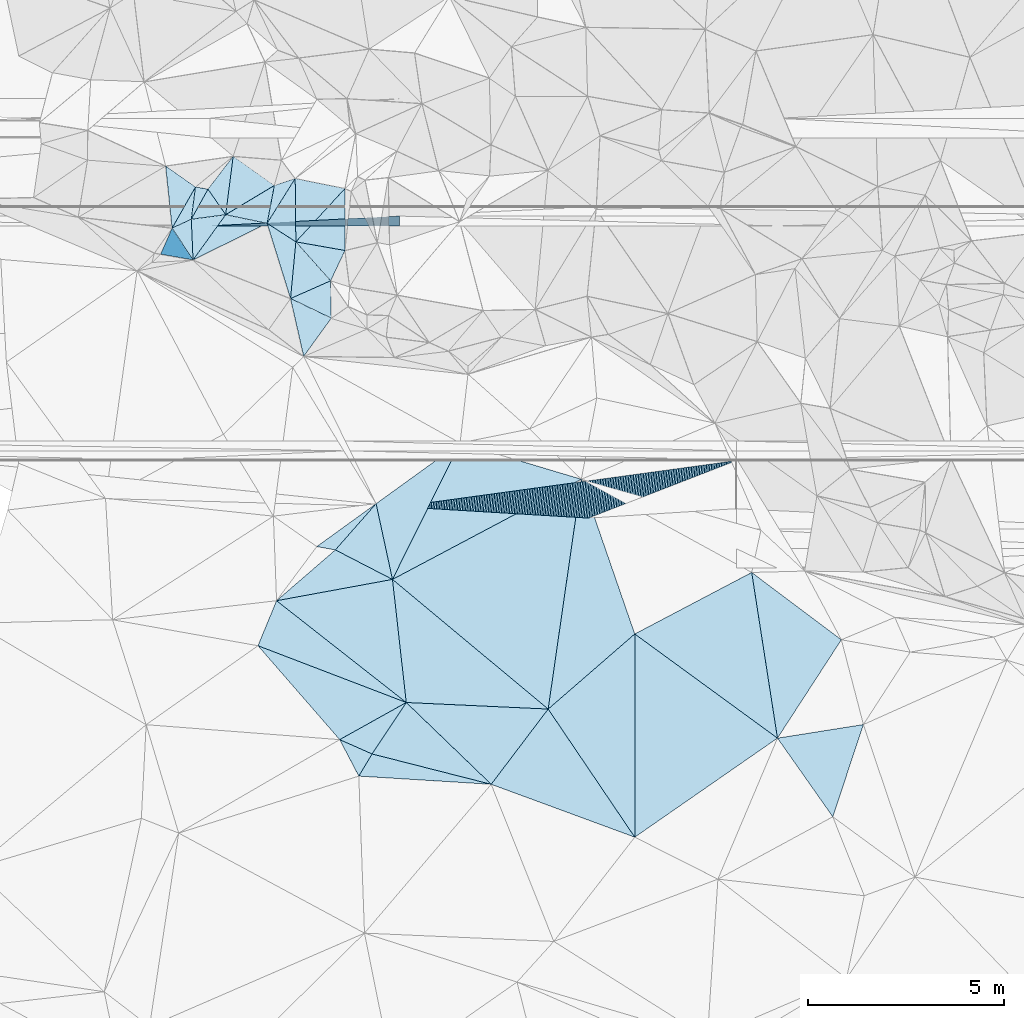
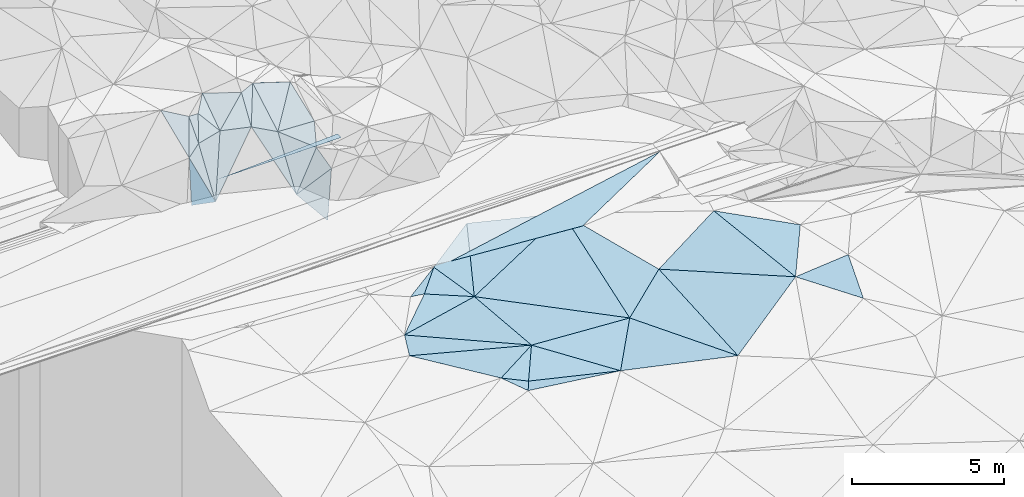
# One storey, part 46 of 275: 48 plates.
"""IFC2X3 building model written with IfcOpenShell, lengths in millimetres."""

from ifc_helpers import new_model, si_unit, frame, origin_with_axes, place, context, subcontext, project, spatial, polyline, outline, extrude, material, type_object, element, save


model = new_model("IFC2X3")

# Units and contexts
model_context = context("Model", 3, precision=1e-05, world=origin_with_axes())
body_context = subcontext(model_context, "Body", "Model", "MODEL_VIEW")
ifc_project = project(units=[si_unit("LENGTHUNIT", "METRE", prefix="MILLI"), si_unit("AREAUNIT", "SQUARE_METRE"), si_unit("VOLUMEUNIT", "CUBIC_METRE"), si_unit("MASSUNIT", "GRAM", prefix="KILO"), si_unit("TIMEUNIT", "SECOND"), si_unit("PLANEANGLEUNIT", "RADIAN"), si_unit("SOLIDANGLEUNIT", "STERADIAN"), si_unit("THERMODYNAMICTEMPERATUREUNIT", "DEGREE_CELSIUS"), si_unit("LUMINOUSINTENSITYUNIT", "LUMEN")], contexts=[model_context])

# Site, building, storey
site_placement = place(None, origin_with_axes())
site = spatial("IfcSite", under=ifc_project, at=site_placement, CompositionType="ELEMENT")
building_placement = place(site_placement, origin_with_axes())
building = spatial("IfcBuilding", under=site, at=building_placement, Name="Undefined", CompositionType="ELEMENT")
storey_placement = place(building_placement, origin_with_axes())
storey = spatial("IfcBuildingStorey", under=building, at=storey_placement, Name="Undefined", CompositionType="ELEMENT", Elevation=0.0)

# Plates
ifc_material = material()
plate_type_1 = type_object("IfcPlateType", PredefinedType="NOTDEFINED")
for number, where, z_axis, x_axis, name in (
    (1, (-134278.700031969, 66044.5731858637, 48859.6831648337), (0.00832149793297365, -0.0249918019511436, -0.9996530210565), (0.998643774165445, 0.0515876520399851, 0.00702328111339566), "00_PR"),
    (2, (-134278.700031969, 66044.5731858637, 48859.6831648337), (0.00832149793297365, -0.0249918019511436, -0.9996530210565), (0.998643774165445, 0.0515876520399851, 0.00702328111339566), "00_PR"),
    (3, (-134278.700031969, 66044.5731858637, 48859.6831648337), (0.00832149793297365, -0.0249918019511436, -0.9996530210565), (0.998643774165445, 0.0515876520399851, 0.00702328111339566), "00_PR"),
):
    element("IfcPlate", number, at=place(storey_placement, frame(where, z_axis=z_axis, x_axis=x_axis)), inside=storey, type_object=plate_type_1, material=ifc_material, Name=name, context=body_context, shape_type="SweptSolid", body=[
        extrude(outline(polyline([(0.0, 0.0), (4840.75732421875, -1.19907781481743e-08), (4827.89013671875, 249.746856689453), (0.0, 0.0)])), frame((-8.85201319254618e-08, 2.18876761149539e-07, -0.5000001331573), z_axis=(0.0, 0.0, 1.0), x_axis=(1.0, 0.0, 0.0)), (0.0, 0.0, 1.0), 1.0),
    ])
plate_type_2 = type_object("IfcPlateType", PredefinedType="NOTDEFINED")
plate_1_placement = place(storey_placement, frame((-132105.806070304, 67257.3645865039, 51279.5756660322), z_axis=(0.143488431826918, 0.509159641083011, -0.848626849577641), x_axis=(0.00906189024525655, -0.858140283939248, -0.513335304869877)))
element("IfcPlate", 4, at=plate_1_placement, inside=storey, type_object=plate_type_2, material=ifc_material, Name="00", context=body_context, shape_type="SweptSolid", body=[
    extrude(outline(polyline([(0.0, 0.0), (1889.60314941406, -3.17231751978397e-09), (1394.41979980469, 737.355712890625), (0.0, 0.0)])), frame((-8.85201319254618e-08, 2.18876761149539e-07, -0.5000001331573), z_axis=(0.0, 0.0, 1.0), x_axis=(1.0, 0.0, 0.0)), (0.0, 0.0, 1.0), 1.0),
])
plate_type_3 = type_object("IfcPlateType", PredefinedType="NOTDEFINED")
plate_2_placement = place(storey_placement, frame((-134654.734859976, 67037.9861247674, 50969.5864879474), z_axis=(0.194931186633535, 0.527354680632889, -0.826981785344893), x_axis=(0.977887294368725, -0.16961479988907, 0.122340750246206)))
element("IfcPlate", 5, at=plate_2_placement, inside=storey, type_object=plate_type_3, material=ifc_material, Name="00", context=body_context, shape_type="SweptSolid", body=[
    extrude(outline(polyline([(0.0, 0.0), (326.955657958984, 4.16184775531292e-09), (-31.502742767334, 995.242492675781), (0.0, 0.0)])), frame((-8.85201319254618e-08, 2.18876761149539e-07, -0.5000001331573), z_axis=(0.0, 0.0, 1.0), x_axis=(1.0, 0.0, 0.0)), (0.0, 0.0, 1.0), 1.0),
])
plate_type_4 = type_object("IfcPlateType", PredefinedType="NOTDEFINED")
plate_3_placement = place(storey_placement, frame((-130037.691105596, 58943.436849099, 48209.4999821093), z_axis=(-0.00131063093471939, -0.00730660715273056, -0.999972447489664), x_axis=(-0.660969339746137, -0.750386046708085, 0.00634923785720053)))
element("IfcPlate", 6, at=plate_3_placement, inside=storey, type_object=plate_type_4, material=ifc_material, Name="00", context=body_context, shape_type="SweptSolid", body=[
    extrude(outline(polyline([(0.0, 0.0), (1574.99206542969, 1.43772922456265e-08), (1825.02502441406, 412.775360107422), (0.0, 0.0)])), frame((-8.85201319254618e-08, 2.18876761149539e-07, -0.5000001331573), z_axis=(0.0, 0.0, 1.0), x_axis=(1.0, 0.0, 0.0)), (0.0, 0.0, 1.0), 1.0),
])
plate_type_5 = type_object("IfcPlateType", PredefinedType="NOTDEFINED")
plate_4_placement = place(storey_placement, frame((-132822.78437554, 66109.4902628047, 50469.673303654), z_axis=(0.304659948241658, 0.693047229450227, -0.653351248325703), x_axis=(0.826595257870964, -0.533188552703511, -0.180139520736486)))
element("IfcPlate", 7, at=plate_4_placement, inside=storey, type_object=plate_type_5, material=ifc_material, Name="00", context=body_context, shape_type="SweptSolid", body=[
    extrude(outline(polyline([(0.0, 0.0), (888.200439453125, -1.60434865392745e-09), (1836.5224609375, 1943.62683105469), (0.0, 0.0)])), frame((-8.85201319254618e-08, 2.18876761149539e-07, -0.5000001331573), z_axis=(0.0, 0.0, 1.0), x_axis=(1.0, 0.0, 0.0)), (0.0, 0.0, 1.0), 1.0),
])
plate_type_6 = type_object("IfcPlateType", PredefinedType="NOTDEFINED")
plate_5_placement = place(storey_placement, frame((-129266.871286603, 53861.2405189074, 47899.5134927947), z_axis=(-0.0107983850297951, 0.230769056659911, -0.972948630385512), x_axis=(0.998692726079005, -0.0461274773168914, -0.0220248657944936)))
element("IfcPlate", 8, at=plate_5_placement, inside=storey, type_object=plate_type_6, material=ifc_material, Name="00", context=body_context, shape_type="SweptSolid", body=[
    extrude(outline(polyline([(0.0, 0.0), (3632.25830078125, 2.32394086197019e-08), (2275.82934570313, 2043.20837402344), (0.0, 0.0)])), frame((-8.85201319254618e-08, 2.18876761149539e-07, -0.5000001331573), z_axis=(0.0, 0.0, 1.0), x_axis=(1.0, 0.0, 0.0)), (0.0, 0.0, 1.0), 1.0),
])
plate_type_7 = type_object("IfcPlateType", PredefinedType="NOTDEFINED")
for number, where, z_axis, x_axis, name in (
    (9, (-120830.616385825, 60044.0391399351, 48952.9577921263), (0.0074723662007596, 0.44720202102918, -0.89440176438264), (-0.915882799607801, -0.355950908885757, -0.185627713033319), "00_PR"),
    (10, (-120830.616385825, 60044.0391399351, 48952.9577921263), (0.0074723662007596, 0.44720202102918, -0.89440176438264), (-0.915882799607801, -0.355950908885757, -0.185627713033319), "00_PR"),
    (11, (-120830.616385825, 60044.0391399351, 48952.9577921263), (0.0074723662007596, 0.44720202102918, -0.89440176438264), (-0.915882799607801, -0.355950908885757, -0.185627713033319), "00_PR"),
):
    element("IfcPlate", number, at=place(storey_placement, frame(where, z_axis=z_axis, x_axis=x_axis)), inside=storey, type_object=plate_type_7, material=ifc_material, Name=name, context=body_context, shape_type="SweptSolid", body=[
        extrude(outline(polyline([(0.0, 0.0), (4127.33642578125, 1.97178451344371e-08), (8431.79296875, 2221.81469726563), (0.0, 0.0)])), frame((-8.85201319254618e-08, 2.18876761149539e-07, -0.5000001331573), z_axis=(0.0, 0.0, 1.0), x_axis=(1.0, 0.0, 0.0)), (0.0, 0.0, 1.0), 1.0),
    ])
plate_type_8 = type_object("IfcPlateType", PredefinedType="NOTDEFINED")
plate_6_placement = place(storey_placement, frame((-133690.586690186, 67824.8999073513, 51089.5456571507), z_axis=(0.300861697588153, 0.289564330805991, -0.908644450403596), x_axis=(0.812040488573359, -0.577396749498086, 0.0848718951513678)))
element("IfcPlate", 12, at=plate_6_placement, inside=storey, type_object=plate_type_8, material=ifc_material, Name="00", context=body_context, shape_type="SweptSolid", body=[
    extrude(outline(polyline([(0.0, 0.0), (1296.07104492188, 4.29645297117531e-09), (661.769287109375, 1458.13623046875), (0.0, 0.0)])), frame((-8.85201319254618e-08, 2.18876761149539e-07, -0.5000001331573), z_axis=(0.0, 0.0, 1.0), x_axis=(1.0, 0.0, 0.0)), (0.0, 0.0, 1.0), 1.0),
])
plate_type_9 = type_object("IfcPlateType", PredefinedType="NOTDEFINED")
plate_7_placement = place(storey_placement, frame((-134760.923733724, 66214.7455942804, 50419.5874471003), z_axis=(0.211448494305168, 0.523954918942359, -0.825082285091726), x_axis=(-0.811240907543192, -0.376753294045777, -0.447152261935635)))
element("IfcPlate", 13, at=plate_7_placement, inside=storey, type_object=plate_type_9, material=ifc_material, Name="00", context=body_context, shape_type="SweptSolid", body=[
    extrude(outline(polyline([(0.0, 0.0), (603.821166992188, 3.78349795937538e-09), (-642.2431640625, 760.936096191406), (0.0, 0.0)])), frame((-8.85201319254618e-08, 2.18876761149539e-07, -0.5000001331573), z_axis=(0.0, 0.0, 1.0), x_axis=(1.0, 0.0, 0.0)), (0.0, 0.0, 1.0), 1.0),
])
plate_type_10 = type_object("IfcPlateType", PredefinedType="NOTDEFINED")
plate_8_placement = place(storey_placement, frame((-134716.304775006, 65174.1068414552, 48689.7760835794), z_axis=(0.124226424866957, 0.885466580296215, -0.447790945133219), x_axis=(-0.982237248685454, 0.173699449781351, 0.0709823107575806)))
element("IfcPlate", 14, at=plate_8_placement, inside=storey, type_object=plate_type_10, material=ifc_material, Name="00", context=body_context, shape_type="SweptSolid", body=[
    extrude(outline(polyline([(0.0, 0.0), (845.281005859375, 6.63567334413528e-09), (769.921447753906, 1576.71203613281), (0.0, 0.0)])), frame((-8.85201319254618e-08, 2.18876761149539e-07, -0.5000001331573), z_axis=(0.0, 0.0, 1.0), x_axis=(1.0, 0.0, 0.0)), (0.0, 0.0, 1.0), 1.0),
])
plate_9_placement = place(storey_placement, frame((-130968.464173493, 52912.2200565433, 47749.5251208357), z_axis=(-0.084485952416159, 0.301574840152359, -0.949691918272138), x_axis=(0.870762785628909, 0.485674587583211, 0.0767617491962)))
element("IfcPlate", 15, at=plate_9_placement, inside=storey, type_object=plate_type_10, material=ifc_material, Name="00", context=body_context, shape_type="SweptSolid", body=[
    extrude(outline(polyline([(0.0, 0.0), (1954.09826660156, 7.29050952941179e-09), (529.2978515625, 759.568176269531), (0.0, 0.0)])), frame((-8.85201319254618e-08, 2.18876761149539e-07, -0.5000001331573), z_axis=(0.0, 0.0, 1.0), x_axis=(1.0, 0.0, 0.0)), (0.0, 0.0, 1.0), 1.0),
])
plate_type_11 = type_object("IfcPlateType", PredefinedType="NOTDEFINED")
plate_10_placement = place(storey_placement, frame((-131078.750894074, 57761.6185573519, 48219.5024007964), z_axis=(-0.0779547068435461, 0.0602454201617392, -0.995134942121154), x_axis=(0.66096933974412, 0.750386046709885, -0.00634923785442994)))
element("IfcPlate", 16, at=plate_10_placement, inside=storey, type_object=plate_type_11, material=ifc_material, Name="00", context=body_context, shape_type="SweptSolid", body=[
    extrude(outline(polyline([(0.0, 0.0), (1574.99206542969, 1.43772922456265e-08), (399.8115234375, 1601.57763671875), (0.0, 0.0)])), frame((-8.85201319254618e-08, 2.18876761149539e-07, -0.5000001331573), z_axis=(0.0, 0.0, 1.0), x_axis=(1.0, 0.0, 0.0)), (0.0, 0.0, 1.0), 1.0),
])
plate_type_12 = type_object("IfcPlateType", PredefinedType="NOTDEFINED")
plate_11_placement = place(storey_placement, frame((-131182.467110191, 63685.4724044839, 49699.6868394499), z_axis=(0.728637537711393, 0.277233087125325, -0.62628200839625), x_axis=(-0.406112399840469, -0.561437595237164, -0.721013554206941)))
element("IfcPlate", 17, at=plate_11_placement, inside=storey, type_object=plate_type_12, material=ifc_material, Name="00", context=body_context, shape_type="SweptSolid", body=[
    extrude(outline(polyline([(0.0, 0.0), (1737.83142089844, -1.40571501106024e-08), (855.26708984375, 1259.17358398438), (0.0, 0.0)])), frame((-8.85201319254618e-08, 2.18876761149539e-07, -0.5000001331573), z_axis=(0.0, 0.0, 1.0), x_axis=(1.0, 0.0, 0.0)), (0.0, 0.0, 1.0), 1.0),
])
plate_type_13 = type_object("IfcPlateType", PredefinedType="NOTDEFINED")
plate_12_placement = place(storey_placement, frame((-132088.783475751, 65635.821456869, 50309.5714804792), z_axis=(-0.0580681217186918, 0.512038489743571, -0.856997478561743), x_axis=(-0.00906189024705845, 0.858140283943332, 0.513335304863019)))
element("IfcPlate", 18, at=plate_12_placement, inside=storey, type_object=plate_type_13, material=ifc_material, Name="00", context=body_context, shape_type="SweptSolid", body=[
    extrude(outline(polyline([(0.0, 0.0), (1889.60314941406, -3.17231751978397e-09), (1534.02587890625, 1271.71728515625), (0.0, 0.0)])), frame((-8.85201319254618e-08, 2.18876761149539e-07, -0.5000001331573), z_axis=(0.0, 0.0, 1.0), x_axis=(1.0, 0.0, 0.0)), (0.0, 0.0, 1.0), 1.0),
])
plate_type_14 = type_object("IfcPlateType", PredefinedType="NOTDEFINED")
plate_13_placement = place(storey_placement, frame((-135417.230248942, 67575.5938815352, 51159.5889484313), z_axis=(0.176779539071753, 0.541263058959853, -0.822060396546994), x_axis=(0.800844409344366, -0.564645672029557, -0.199558254853473)))
element("IfcPlate", 19, at=plate_13_placement, inside=storey, type_object=plate_type_14, material=ifc_material, Name="00", context=body_context, shape_type="SweptSolid", body=[
    extrude(outline(polyline([(0.0, 0.0), (952.102905273438, 3.53611540049315e-09), (1231.69458007813, 1433.01379394531), (0.0, 0.0)])), frame((-8.85201319254618e-08, 2.18876761149539e-07, -0.5000001331573), z_axis=(0.0, 0.0, 1.0), x_axis=(1.0, 0.0, 0.0)), (0.0, 0.0, 1.0), 1.0),
])
plate_type_15 = type_object("IfcPlateType", PredefinedType="NOTDEFINED")
plate_14_placement = place(storey_placement, frame((-132088.67326878, 65635.7881798895, 50309.5597556837), z_axis=(0.162348387343024, 0.445483742764, -0.880447179596878), x_axis=(0.980586786824821, -0.172279698787597, 0.0936443211851553)))
element("IfcPlate", 20, at=plate_14_placement, inside=storey, type_object=plate_type_15, material=ifc_material, Name="00", context=body_context, shape_type="SweptSolid", body=[
    extrude(outline(polyline([(0.0, 0.0), (1281.44445800781, -2.19733919948339e-09), (1010.96850585938, 935.169921875), (0.0, 0.0)])), frame((-8.85201319254618e-08, 2.18876761149539e-07, -0.5000001331573), z_axis=(0.0, 0.0, 1.0), x_axis=(1.0, 0.0, 0.0)), (0.0, 0.0, 1.0), 1.0),
])
plate_type_16 = type_object("IfcPlateType", PredefinedType="NOTDEFINED")
plate_15_placement = place(storey_placement, frame((-134335.086056122, 66982.5631335924, 51009.5984188031), z_axis=(0.0410071430476353, 0.594405866955433, -0.80311896973489), x_axis=(0.493071067297978, -0.711142498049694, -0.501155933878144)))
element("IfcPlate", 21, at=plate_15_placement, inside=storey, type_object=plate_type_16, material=ifc_material, Name="00", context=body_context, shape_type="SweptSolid", body=[
    extrude(outline(polyline([(0.0, 0.0), (917.877990722656, -2.57568899542093e-09), (631.674377441406, 848.520751953125), (0.0, 0.0)])), frame((-8.85201319254618e-08, 2.18876761149539e-07, -0.5000001331573), z_axis=(0.0, 0.0, 1.0), x_axis=(1.0, 0.0, 0.0)), (0.0, 0.0, 1.0), 1.0),
])
plate_type_17 = type_object("IfcPlateType", PredefinedType="NOTDEFINED")
plate_16_placement = place(storey_placement, frame((-130479.879628039, 51979.9902730415, 47639.5037443291), z_axis=(-0.0819031668446331, -0.0910612296835025, -0.992471522870731), x_axis=(0.511533833442366, 0.850803497360804, -0.120276955907532)))
element("IfcPlate", 22, at=plate_16_placement, inside=storey, type_object=plate_type_17, material=ifc_material, Name="00", context=body_context, shape_type="SweptSolid", body=[
    extrude(outline(polyline([(0.0, 0.0), (665.131591796875, -3.05590219795704e-09), (1583.74682617188, 3008.828125), (0.0, 0.0)])), frame((-8.85201319254618e-08, 2.18876761149539e-07, -0.5000001331573), z_axis=(0.0, 0.0, 1.0), x_axis=(1.0, 0.0, 0.0)), (0.0, 0.0, 1.0), 1.0),
])
plate_type_18 = type_object("IfcPlateType", PredefinedType="NOTDEFINED")
plate_17_placement = place(storey_placement, frame((-131182.46950991, 63685.4337940877, 49699.6698042662), z_axis=(0.723831856703336, 0.200010420986222, -0.660350872429435), x_axis=(-0.684403235767947, 0.32952742876265, -0.650387488012677)))
element("IfcPlate", 23, at=plate_17_placement, inside=storey, type_object=plate_type_18, material=ifc_material, Name="00", context=body_context, shape_type="SweptSolid", body=[
    extrude(outline(polyline([(0.0, 0.0), (1522.16955566406, -8.1636244431138e-09), (150.837341308594, 980.534606933594), (0.0, 0.0)])), frame((-8.85201319254618e-08, 2.18876761149539e-07, -0.5000001331573), z_axis=(0.0, 0.0, 1.0), x_axis=(1.0, 0.0, 0.0)), (0.0, 0.0, 1.0), 1.0),
])
plate_type_19 = type_object("IfcPlateType", PredefinedType="NOTDEFINED")
plate_18_placement = place(storey_placement, frame((-129619.116809642, 57007.4016242985, 48059.501400801), z_axis=(-0.0201347535323269, 0.0729012462380124, -0.997135898459752), x_axis=(-0.210716372765427, 0.974626481330318, 0.0755104770099159)))
element("IfcPlate", 24, at=plate_18_placement, inside=storey, type_object=plate_type_19, material=ifc_material, Name="00", context=body_context, shape_type="SweptSolid", body=[
    extrude(outline(polyline([(0.0, 0.0), (1986.47924804688, -3.17231751978397e-09), (3050.421875, 2425.59814453125), (0.0, 0.0)])), frame((-8.85201319254618e-08, 2.18876761149539e-07, -0.5000001331573), z_axis=(0.0, 0.0, 1.0), x_axis=(1.0, 0.0, 0.0)), (0.0, 0.0, 1.0), 1.0),
])
plate_type_20 = type_object("IfcPlateType", PredefinedType="NOTDEFINED")
plate_19_placement = place(storey_placement, frame((-133882.707623126, 66329.7025846088, 50549.5691540783), z_axis=(-0.360311098108989, 0.357399813960917, -0.861650326733645), x_axis=(-0.493071067275053, 0.711142498044462, 0.501155933908122)))
element("IfcPlate", 25, at=plate_19_placement, inside=storey, type_object=plate_type_20, material=ifc_material, Name="00", context=body_context, shape_type="SweptSolid", body=[
    extrude(outline(polyline([(0.0, 0.0), (917.877990722656, -2.57568899542093e-09), (1239.38037109375, 1013.92120361328), (0.0, 0.0)])), frame((-8.85201319254618e-08, 2.18876761149539e-07, -0.5000001331573), z_axis=(0.0, 0.0, 1.0), x_axis=(1.0, 0.0, 0.0)), (0.0, 0.0, 1.0), 1.0),
])
plate_type_21 = type_object("IfcPlateType", PredefinedType="NOTDEFINED")
plate_20_placement = place(storey_placement, frame((-130832.111642573, 65414.9761483001, 50429.5386871541), z_axis=(0.15050739044198, 0.355171225931698, -0.922605509246786), x_axis=(-0.980586786832412, 0.172279698784067, -0.0936443211121573)))
element("IfcPlate", 26, at=plate_20_placement, inside=storey, type_object=plate_type_21, material=ifc_material, Name="00", context=body_context, shape_type="SweptSolid", body=[
    extrude(outline(polyline([(0.0, 0.0), (1281.44445800781, -2.19733919948339e-09), (216.864639282227, 1684.39001464844), (0.0, 0.0)])), frame((-8.85201319254618e-08, 2.18876761149539e-07, -0.5000001331573), z_axis=(0.0, 0.0, 1.0), x_axis=(1.0, 0.0, 0.0)), (0.0, 0.0, 1.0), 1.0),
])
plate_type_22 = type_object("IfcPlateType", PredefinedType="NOTDEFINED")
plate_21_placement = place(storey_placement, frame((-132822.98124532, 66109.4491292035, 50469.606605966), z_axis=(-0.0890854308744195, 0.610786022629736, -0.786768212732356), x_axis=(0.150645141767562, 0.78908434604381, 0.595526604015677)))
element("IfcPlate", 27, at=plate_21_placement, inside=storey, type_object=plate_type_22, material=ifc_material, Name="00", context=body_context, shape_type="SweptSolid", body=[
    extrude(outline(polyline([(0.0, 0.0), (1225.80590820313, 1.07684172689915e-09), (1496.240234375, 499.364868164063), (0.0, 0.0)])), frame((-8.85201319254618e-08, 2.18876761149539e-07, -0.5000001331573), z_axis=(0.0, 0.0, 1.0), x_axis=(1.0, 0.0, 0.0)), (0.0, 0.0, 1.0), 1.0),
])
plate_type_23 = type_object("IfcPlateType", PredefinedType="NOTDEFINED")
plate_22_placement = place(storey_placement, frame((-133882.496032568, 66329.8206498878, 50549.5988153538), z_axis=(0.0628690097844496, 0.593535002253485, -0.802348857236476), x_axis=(0.782486817871272, 0.469701250168756, 0.408772694107128)))
element("IfcPlate", 28, at=plate_22_placement, inside=storey, type_object=plate_type_23, material=ifc_material, Name="00", context=body_context, shape_type="SweptSolid", body=[
    extrude(outline(polyline([(0.0, 0.0), (1590.12573242188, -7.45058059692383e-09), (692.901184082031, 835.217346191406), (0.0, 0.0)])), frame((-8.85201319254618e-08, 2.18876761149539e-07, -0.5000001331573), z_axis=(0.0, 0.0, 1.0), x_axis=(1.0, 0.0, 0.0)), (0.0, 0.0, 1.0), 1.0),
])
plate_type_24 = type_object("IfcPlateType", PredefinedType="NOTDEFINED")
plate_23_placement = place(storey_placement, frame((-131200.012071459, 64640.1113544458, 49969.693630268), z_axis=(0.474139208169531, 0.63227341815485, -0.612717174535816), x_axis=(-0.607631923635289, -0.268631263072983, -0.747409318833457)))
element("IfcPlate", 29, at=plate_23_placement, inside=storey, type_object=plate_type_24, material=ifc_material, Name="00", context=body_context, shape_type="SweptSolid", body=[
    extrude(outline(polyline([(0.0, 0.0), (1685.8232421875, 3.98722477257252e-09), (18.2700061798096, 1377.0498046875), (0.0, 0.0)])), frame((-8.85201319254618e-08, 2.18876761149539e-07, -0.5000001331573), z_axis=(0.0, 0.0, 1.0), x_axis=(1.0, 0.0, 0.0)), (0.0, 0.0, 1.0), 1.0),
])
plate_type_25 = type_object("IfcPlateType", PredefinedType="NOTDEFINED")
plate_24_placement = place(storey_placement, frame((-134761.04732935, 66214.9115771292, 50419.7420530097), z_axis=(-0.0357451888623837, 0.855920690884108, -0.51587018947567), x_axis=(0.981030794876753, 0.128466464212132, 0.145172129130627)))
element("IfcPlate", 30, at=plate_24_placement, inside=storey, type_object=plate_type_25, material=ifc_material, Name="00", context=body_context, shape_type="SweptSolid", body=[
    extrude(outline(polyline([(0.0, 0.0), (895.488708496094, 3.34694050252438e-10), (-341.042846679688, 1990.44958496094), (0.0, 0.0)])), frame((-8.85201319254618e-08, 2.18876761149539e-07, -0.5000001331573), z_axis=(0.0, 0.0, 1.0), x_axis=(1.0, 0.0, 0.0)), (0.0, 0.0, 1.0), 1.0),
])
plate_type_26 = type_object("IfcPlateType", PredefinedType="NOTDEFINED")
plate_25_placement = place(storey_placement, frame((-133057.363777679, 55312.3817425411, 47919.5001170615), z_axis=(-0.0131716766393589, -0.0206255066117845, -0.999700502856488), x_axis=(0.3817976895206, 0.923931851586826, -0.024092693914769)))
element("IfcPlate", 31, at=plate_25_placement, inside=storey, type_object=plate_type_26, material=ifc_material, Name="00", context=body_context, shape_type="SweptSolid", body=[
    extrude(outline(polyline([(0.0, 0.0), (1245.19079589844, -6.69388100504875e-10), (106.810943603516, 4057.46118164063), (0.0, 0.0)])), frame((-8.85201319254618e-08, 2.18876761149539e-07, -0.5000001331573), z_axis=(0.0, 0.0, 1.0), x_axis=(1.0, 0.0, 0.0)), (0.0, 0.0, 1.0), 1.0),
])
plate_type_27 = type_object("IfcPlateType", PredefinedType="NOTDEFINED")
plate_26_placement = place(storey_placement, frame((-132581.922794237, 56462.8914330069, 47889.5013155693), z_axis=(0.0469374717700572, 0.0559734260094784, -0.997328355820989), x_axis=(0.981966724071135, 0.180462888693857, 0.0563426891554988)))
element("IfcPlate", 32, at=plate_26_placement, inside=storey, type_object=plate_type_27, material=ifc_material, Name="00", context=body_context, shape_type="SweptSolid", body=[
    extrude(outline(polyline([(0.0, 0.0), (3017.25048828125, 2.84198904410005e-08), (2786.3447265625, 3161.51586914063), (0.0, 0.0)])), frame((-8.85201319254618e-08, 2.18876761149539e-07, -0.5000001331573), z_axis=(0.0, 0.0, 1.0), x_axis=(1.0, 0.0, 0.0)), (0.0, 0.0, 1.0), 1.0),
])
plate_type_28 = type_object("IfcPlateType", PredefinedType="NOTDEFINED")
plate_27_placement = place(storey_placement, frame((-134716.30332538, 65174.0720653033, 48689.7179684254), z_axis=(0.127115393605729, 0.815917510021166, -0.564021536423319), x_axis=(0.35584482460917, 0.493268501908025, 0.793763595678387)))
element("IfcPlate", 33, at=plate_27_placement, inside=storey, type_object=plate_type_28, material=ifc_material, Name="00", context=body_context, shape_type="SweptSolid", body=[
    extrude(outline(polyline([(0.0, 0.0), (2343.26684570313, -7.27595761418343e-10), (2548.10913085938, 1065.71081542969), (0.0, 0.0)])), frame((-8.85201319254618e-08, 2.18876761149539e-07, -0.5000001331573), z_axis=(0.0, 0.0, 1.0), x_axis=(1.0, 0.0, 0.0)), (0.0, 0.0, 1.0), 1.0),
])
plate_type_29 = type_object("IfcPlateType", PredefinedType="NOTDEFINED")
plate_28_placement = place(storey_placement, frame((-134716.42255391, 65174.0892458268, 48689.7427653996), z_axis=(-0.111332912892545, 0.850276871637069, -0.514426111376493), x_axis=(-0.304622976280098, 0.463526887066782, 0.832074315964886)))
element("IfcPlate", 34, at=plate_28_placement, inside=storey, type_object=plate_type_29, material=ifc_material, Name="00", context=body_context, shape_type="SweptSolid", body=[
    extrude(outline(polyline([(0.0, 0.0), (1754.65100097656, 8.81846062839031e-09), (1935.54162597656, 576.089050292969), (0.0, 0.0)])), frame((-8.85201319254618e-08, 2.18876761149539e-07, -0.5000001331573), z_axis=(0.0, 0.0, 1.0), x_axis=(1.0, 0.0, 0.0)), (0.0, 0.0, 1.0), 1.0),
])
plate_type_30 = type_object("IfcPlateType", PredefinedType="NOTDEFINED")
plate_29_placement = place(storey_placement, frame((-123426.256521315, 50418.8276089938, 47519.5014034848), z_axis=(-0.0442541529563969, 0.0614389016251529, -0.997129295183532), x_axis=(-0.558326395432462, 0.826161949413294, 0.0756840108941132)))
element("IfcPlate", 35, at=plate_29_placement, inside=storey, type_object=plate_type_30, material=ifc_material, Name="00", context=body_context, shape_type="SweptSolid", body=[
    extrude(outline(polyline([(0.0, 0.0), (3963.84912109375, 6.40284270048141e-10), (4314.87158203125, 2908.05493164063), (0.0, 0.0)])), frame((-8.85201319254618e-08, 2.18876761149539e-07, -0.5000001331573), z_axis=(0.0, 0.0, 1.0), x_axis=(1.0, 0.0, 0.0)), (0.0, 0.0, 1.0), 1.0),
])
plate_type_31 = type_object("IfcPlateType", PredefinedType="NOTDEFINED")
plate_30_placement = place(storey_placement, frame((-127096.048022643, 51770.3997227298, 47379.5081580064), z_axis=(0.0941380713863919, 0.153727705727702, -0.983618735083542), x_axis=(0.59398899947007, 0.784212169456794, 0.179411097160724)))
element("IfcPlate", 36, at=plate_30_placement, inside=storey, type_object=plate_type_31, material=ifc_material, Name="00", context=body_context, shape_type="SweptSolid", body=[
    extrude(outline(polyline([(0.0, 0.0), (2452.46826171875, -1.35332811623812e-09), (1145.09130859375, 3742.04028320313), (0.0, 0.0)])), frame((-8.85201319254618e-08, 2.18876761149539e-07, -0.5000001331573), z_axis=(0.0, 0.0, 1.0), x_axis=(1.0, 0.0, 0.0)), (0.0, 0.0, 1.0), 1.0),
])
plate_type_32 = type_object("IfcPlateType", PredefinedType="NOTDEFINED")
plate_31_placement = place(storey_placement, frame((-129266.849600156, 53861.1745292881, 47899.5026797624), z_axis=(0.0325758109802664, 0.0987894268572773, -0.9945750176232), x_axis=(-0.870762785630425, -0.485674587580499, -0.0767617491961705)))
element("IfcPlate", 37, at=plate_31_placement, inside=storey, type_object=plate_type_32, material=ifc_material, Name="00", context=body_context, shape_type="SweptSolid", body=[
    extrude(outline(polyline([(0.0, 0.0), (1954.09826660156, 7.29050952941179e-09), (2594.23999023438, 3121.58911132813), (0.0, 0.0)])), frame((-8.85201319254618e-08, 2.18876761149539e-07, -0.5000001331573), z_axis=(0.0, 0.0, 1.0), x_axis=(1.0, 0.0, 0.0)), (0.0, 0.0, 1.0), 1.0),
])
plate_type_33 = type_object("IfcPlateType", PredefinedType="NOTDEFINED")
plate_32_placement = place(storey_placement, frame((-127096.092300925, 51770.446263846, 47379.5154437448), z_axis=(0.00558530040666459, 0.246809258005109, -0.969047983632562), x_axis=(-0.967441266583232, 0.246543390442689, 0.0572167138243345)))
element("IfcPlate", 38, at=plate_32_placement, inside=storey, type_object=plate_type_33, material=ifc_material, Name="00", context=body_context, shape_type="SweptSolid", body=[
    extrude(outline(polyline([(0.0, 0.0), (3145.93383789063, -6.11544237472117e-09), (2645.3193359375, 1535.05212402344), (0.0, 0.0)])), frame((-8.85201319254618e-08, 2.18876761149539e-07, -0.5000001331573), z_axis=(0.0, 0.0, 1.0), x_axis=(1.0, 0.0, 0.0)), (0.0, 0.0, 1.0), 1.0),
])
plate_type_34 = type_object("IfcPlateType", PredefinedType="NOTDEFINED")
plate_33_placement = place(storey_placement, frame((-119778.161237539, 52950.0467416147, 47869.5029163965), z_axis=(0.0691240817494461, 0.0835147709701101, -0.994106203758988), x_axis=(-0.807747125780622, 0.589491692725749, -0.00664266516353758)))
element("IfcPlate", 39, at=plate_33_placement, inside=storey, type_object=plate_type_34, material=ifc_material, Name="00", context=body_context, shape_type="SweptSolid", body=[
    extrude(outline(polyline([(0.0, 0.0), (4516.25927734375, 1.85864337254316e-08), (3026.73046875, 3050.68896484375), (0.0, 0.0)])), frame((-8.85201319254618e-08, 2.18876761149539e-07, -0.5000001331573), z_axis=(0.0, 0.0, 1.0), x_axis=(1.0, 0.0, 0.0)), (0.0, 0.0, 1.0), 1.0),
])
plate_type_35 = type_object("IfcPlateType", PredefinedType="NOTDEFINED")
plate_34_placement = place(storey_placement, frame((-117581.33790763, 53298.0359764834, 47779.5008528672), z_axis=(-0.0467057406989856, 0.0366820613815821, -0.998234942365051), x_axis=(-0.315206911381457, -0.948809715279886, -0.0201178330807055)))
element("IfcPlate", 40, at=plate_34_placement, inside=storey, type_object=plate_type_35, material=ifc_material, Name="00", context=body_context, shape_type="SweptSolid", body=[
    extrude(outline(polyline([(0.0, 0.0), (2485.35717773438, -9.16770659387112e-10), (1020.85931396484, 1978.21789550781), (0.0, 0.0)])), frame((-8.85201319254618e-08, 2.18876761149539e-07, -0.5000001331573), z_axis=(0.0, 0.0, 1.0), x_axis=(1.0, 0.0, 0.0)), (0.0, 0.0, 1.0), 1.0),
])
plate_type_36 = type_object("IfcPlateType", PredefinedType="NOTDEFINED")
plate_35_placement = place(storey_placement, frame((-125639.379426464, 53693.610452668, 47819.5015597455), z_axis=(-0.0468731150262899, 0.0644565268619393, -0.996819074472709), x_axis=(0.142508411302679, 0.988139756898903, 0.0571941740369064)))
element("IfcPlate", 41, at=plate_35_placement, inside=storey, type_object=plate_type_36, material=ifc_material, Name="00", context=body_context, shape_type="SweptSolid", body=[
    extrude(outline(polyline([(0.0, 0.0), (5944.66162109375, -9.83709469437599e-09), (2212.50610351563, 1919.58764648438), (0.0, 0.0)])), frame((-8.85201319254618e-08, 2.18876761149539e-07, -0.5000001331573), z_axis=(0.0, 0.0, 1.0), x_axis=(1.0, 0.0, 0.0)), (0.0, 0.0, 1.0), 1.0),
])
plate_type_37 = type_object("IfcPlateType", PredefinedType="NOTDEFINED")
plate_36_placement = place(storey_placement, frame((-120437.011987115, 57185.328973594, 48179.5030891743), z_axis=(-0.0953018134435254, 0.0579143768334981, -0.993762290143052), x_axis=(0.794731535950139, -0.596726772117204, -0.110990743780348)))
element("IfcPlate", 42, at=plate_36_placement, inside=storey, type_object=plate_type_37, material=ifc_material, Name="00", context=body_context, shape_type="SweptSolid", body=[
    extrude(outline(polyline([(0.0, 0.0), (2883.12329101563, 1.43845682032406e-08), (3085.26513671875, 2991.47778320313), (0.0, 0.0)])), frame((-8.85201319254618e-08, 2.18876761149539e-07, -0.5000001331573), z_axis=(0.0, 0.0, 1.0), x_axis=(1.0, 0.0, 0.0)), (0.0, 0.0, 1.0), 1.0),
])
plate_type_38 = type_object("IfcPlateType", PredefinedType="NOTDEFINED")
plate_37_placement = place(storey_placement, frame((-129619.11663305, 57007.3894585513, 48059.5006566193), z_axis=(-0.019780009072481, 0.0485698790396646, -0.998623912236816), x_axis=(0.76765107433487, -0.639193826410658, -0.0462934158495761)))
element("IfcPlate", 43, at=plate_37_placement, inside=storey, type_object=plate_type_38, material=ifc_material, Name="00", context=body_context, shape_type="SweptSolid", body=[
    extrude(outline(polyline([(0.0, 0.0), (5184.32275390625, 1.88520061783493e-08), (2288.8623046875, 2193.08227539063), (0.0, 0.0)])), frame((-8.85201319254618e-08, 2.18876761149539e-07, -0.5000001331573), z_axis=(0.0, 0.0, 1.0), x_axis=(1.0, 0.0, 0.0)), (0.0, 0.0, 1.0), 1.0),
])
plate_type_39 = type_object("IfcPlateType", PredefinedType="NOTDEFINED")
plate_38_placement = place(storey_placement, frame((-132581.939637583, 56462.9793861749, 47889.5136398024), z_axis=(0.0131953241175619, 0.231874266587003, -0.972656264009116), x_axis=(0.746474863583176, 0.644919786533198, 0.163871129173061)))
element("IfcPlate", 44, at=plate_38_placement, inside=storey, type_object=plate_type_39, material=ifc_material, Name="00", context=body_context, shape_type="SweptSolid", body=[
    extrude(outline(polyline([(0.0, 0.0), (2013.77758789063, 1.12922862172127e-08), (2590.703125, 1546.62756347656), (0.0, 0.0)])), frame((-8.85201319254618e-08, 2.18876761149539e-07, -0.5000001331573), z_axis=(0.0, 0.0, 1.0), x_axis=(1.0, 0.0, 0.0)), (0.0, 0.0, 1.0), 1.0),
])
plate_type_40 = type_object("IfcPlateType", PredefinedType="NOTDEFINED")
plate_39_placement = place(storey_placement, frame((-124792.197145195, 59567.7642296417, 48159.5008916691), z_axis=(-0.0107922355643492, 0.0593317528161232, -0.998179979141683), x_axis=(-0.142508411295809, -0.988139756899178, -0.0571941740492644)))
element("IfcPlate", 45, at=plate_39_placement, inside=storey, type_object=plate_type_40, material=ifc_material, Name="00", context=body_context, shape_type="SweptSolid", body=[
    extrude(outline(polyline([(0.0, 0.0), (5944.66162109375, -9.83709469437599e-09), (3223.59814453125, 4412.82373046875), (0.0, 0.0)])), frame((-8.85201319254618e-08, 2.18876761149539e-07, -0.5000001331573), z_axis=(0.0, 0.0, 1.0), x_axis=(1.0, 0.0, 0.0)), (0.0, 0.0, 1.0), 1.0),
])
plate_type_41 = type_object("IfcPlateType", PredefinedType="NOTDEFINED")
plate_40_placement = place(storey_placement, frame((-127891.255542214, 60493.7600948601, 48279.5013351044), z_axis=(-0.0172571160223412, 0.0714849473039201, -0.997292381528881), x_axis=(0.957484080597344, -0.286093804467993, -0.0370751999008575)))
element("IfcPlate", 46, at=plate_40_placement, inside=storey, type_object=plate_type_41, material=ifc_material, Name="00", context=body_context, shape_type="SweptSolid", body=[
    extrude(outline(polyline([(0.0, 0.0), (3236.6650390625, -6.03176886215806e-09), (-648.815979003906, 3842.86840820313), (0.0, 0.0)])), frame((-8.85201319254618e-08, 2.18876761149539e-07, -0.5000001331573), z_axis=(0.0, 0.0, 1.0), x_axis=(1.0, 0.0, 0.0)), (0.0, 0.0, 1.0), 1.0),
])
plate_type_42 = type_object("IfcPlateType", PredefinedType="NOTDEFINED")
plate_41_placement = place(storey_placement, frame((-130479.950970438, 51980.0344407238, 47639.5127549973), z_axis=(-0.22458848187391, -0.00272596297574292, -0.974449887339224), x_axis=(-0.461770887496686, 0.880885492459275, 0.103963438935541)))
element("IfcPlate", 47, at=plate_41_placement, inside=storey, type_object=plate_type_42, material=ifc_material, Name="00", context=body_context, shape_type="SweptSolid", body=[
    extrude(outline(polyline([(0.0, 0.0), (1058.06433105469, 5.67524693906307e-09), (333.061065673828, 575.734619140625), (0.0, 0.0)])), frame((-8.85201319254618e-08, 2.18876761149539e-07, -0.5000001331573), z_axis=(0.0, 0.0, 1.0), x_axis=(1.0, 0.0, 0.0)), (0.0, 0.0, 1.0), 1.0),
])
plate_type_43 = type_object("IfcPlateType", PredefinedType="NOTDEFINED")
plate_42_placement = place(storey_placement, frame((-123426.164961281, 55612.3331562706, 47839.5016286973), z_axis=(0.0530148008486902, 0.0614118661933477, -0.996703573577232), x_axis=(0.807747125789969, -0.589491692713526, 0.00664266511163565)))
element("IfcPlate", 48, at=plate_42_placement, inside=storey, type_object=plate_type_43, material=ifc_material, Name="00", context=body_context, shape_type="SweptSolid", body=[
    extrude(outline(polyline([(0.0, 0.0), (4516.25927734375, 1.85864337254316e-08), (3059.36791992188, 4208.93896484375), (0.0, 0.0)])), frame((-8.85201319254618e-08, 2.18876761149539e-07, -0.5000001331573), z_axis=(0.0, 0.0, 1.0), x_axis=(1.0, 0.0, 0.0)), (0.0, 0.0, 1.0), 1.0),
])

save(model, "model.ifc")
